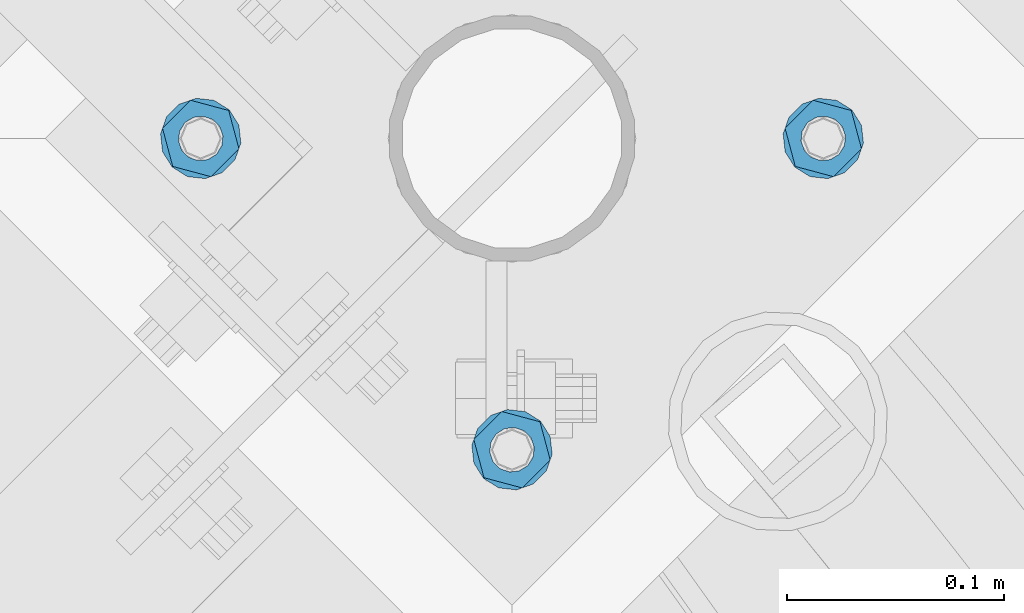
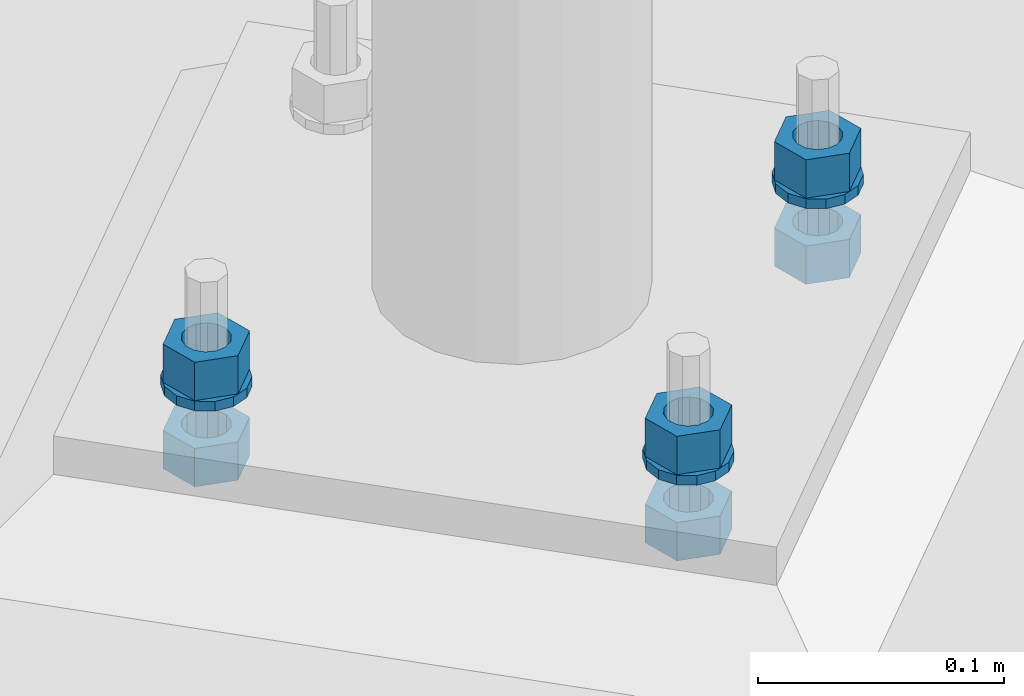
# One storey, part 825 of 975: 9 beams.
"""IFC2X3 building model written with IfcOpenShell, lengths in millimetres."""

from ifc_helpers import new_model, si_unit, frame, origin_with_axes, place, context, subcontext, project, spatial, faceted_brep, material, type_object, element, save


model = new_model("IFC2X3")

# Units and contexts
model_context = context("Model", 3, precision=1e-05, world=origin_with_axes())
body_context = subcontext(model_context, "Body", "Model", "MODEL_VIEW")
ifc_project = project(units=[si_unit("LENGTHUNIT", "METRE", prefix="MILLI"), si_unit("AREAUNIT", "SQUARE_METRE"), si_unit("VOLUMEUNIT", "CUBIC_METRE"), si_unit("MASSUNIT", "GRAM", prefix="KILO"), si_unit("TIMEUNIT", "SECOND"), si_unit("PLANEANGLEUNIT", "RADIAN"), si_unit("SOLIDANGLEUNIT", "STERADIAN"), si_unit("THERMODYNAMICTEMPERATUREUNIT", "DEGREE_CELSIUS"), si_unit("LUMINOUSINTENSITYUNIT", "LUMEN")], contexts=[model_context])

# Site, building, storey
site_placement = place(None, origin_with_axes())
site = spatial("IfcSite", under=ifc_project, at=site_placement, CompositionType="ELEMENT")
building_placement = place(site_placement, origin_with_axes())
building = spatial("IfcBuilding", under=site, at=building_placement, Name="Undefined", CompositionType="ELEMENT")
storey_placement = place(building_placement, origin_with_axes())
storey = spatial("IfcBuildingStorey", under=building, at=storey_placement, Name="Undefined", CompositionType="ELEMENT", Elevation=0.0)

# Beams
ifc_material = material(Name="STEEL/A36")
beam_type_1 = type_object("IfcBeamType", Name="3/4_WASHER", PredefinedType="NOTDEFINED")
beam_1_placement = place(storey_placement, frame((35537.7749989074, 12953.1909055685, -242.8875), z_axis=(0.707106781186513, -0.707106781186582, 3.1377567211166e-14), x_axis=(0.0, 0.0, -1.0)))
element("IfcBeam", 1, at=beam_1_placement, inside=storey, type_object=beam_type_1, material=ifc_material, Name="WASHER", ObjectType="3/4_WASHER", context=body_context, shape_type="Brep", body=[
    faceted_brep([(0.0, -18.6499996185303, 0.0), (0.0, -16.8030690426876, -8.09193156902904), (4.76250000000073, -16.8030690426876, -8.09193156902904), (4.76250000000073, -18.6499996185303, 0.0), (0.0, -11.6280845668225, -14.5811568497838), (4.76250000000073, -11.6280845668225, -14.5811568497838), (0.0, -4.15001533340001, -18.1824051902857), (4.76250000000073, -4.15001533340001, -18.1824051902857), (0.0, 4.15001533340001, -18.1824051902857), (4.76250000000073, 4.15001533340001, -18.1824051902857), (0.0, 11.6280845668234, -14.5811568497838), (4.76250000000073, 11.6280845668234, -14.5811568497838), (0.0, 16.8030690426876, -8.09193156902904), (4.76250000000073, 16.8030690426876, -8.09193156902904), (0.0, 18.6499996185303, 0.0), (4.76250000000073, 18.6499996185303, 0.0), (0.0, 16.8030690426876, 8.09193156902904), (4.76250000000073, 16.8030690426876, 8.09193156902904), (0.0, 11.6280845668225, 14.5811568497838), (4.76250000000073, 11.6280845668225, 14.5811568497838), (0.0, 4.15001533340001, 18.1824051902857), (4.76250000000073, 4.15001533340001, 18.1824051902857), (0.0, -4.15001533340001, 18.1824051902857), (4.76250000000073, -4.15001533340001, 18.1824051902857), (0.0, -11.6280845668234, 14.5811568497838), (4.76250000000073, -11.6280845668234, 14.5811568497838), (0.0, -16.8030690426876, 8.09193156902904), (4.76250000000073, -16.8030690426876, 8.09193156902904), (0.0, 0.0, 10.3199996948242), (0.0, 4.47768005528269, 9.29799844179911), (4.76250000000073, 4.47768005528269, 9.29799844179911), (4.76250000000073, 0.0, 10.3199996948242), (0.0, 8.06850066047446, 6.43441456490817), (4.76250000000073, 8.06850066047446, 6.43441456490817), (0.0, 10.0612557561917, 2.29641597052117), (4.76250000000073, 10.0612557561917, 2.29641597052117), (0.0, 10.0612557561917, -2.29641597052117), (4.76250000000073, 10.0612557561917, -2.29641597052117), (0.0, 8.06850066047446, -6.43441456490814), (4.76250000000073, 8.06850066047446, -6.43441456490814), (0.0, 4.47768005528269, -9.29799844179908), (4.76250000000073, 4.47768005528269, -9.29799844179908), (0.0, 0.0, -10.3199996948242), (4.76250000000073, 0.0, -10.3199996948242), (0.0, -4.47768005528269, -9.29799844179911), (4.76250000000073, -4.47768005528269, -9.29799844179911), (0.0, -8.06850066047446, -6.43441456490817), (4.76250000000073, -8.06850066047446, -6.43441456490817), (0.0, -10.0612557561917, -2.29641597052117), (4.76250000000073, -10.0612557561917, -2.29641597052117), (0.0, -10.0612557561917, 2.29641597052117), (4.76250000000073, -10.0612557561917, 2.29641597052117), (0.0, -8.06850066047446, 6.43441456490814), (4.76250000000073, -8.06850066047446, 6.43441456490814), (0.0, -4.47768005528269, 9.29799844179908), (4.76250000000073, -4.47768005528269, 9.29799844179908)], [[[0, 1, 2, 3]], [[1, 4, 5, 2]], [[4, 6, 7, 5]], [[6, 8, 9, 7]], [[8, 10, 11, 9]], [[10, 12, 13, 11]], [[12, 14, 15, 13]], [[14, 16, 17, 15]], [[16, 18, 19, 17]], [[18, 20, 21, 19]], [[20, 22, 23, 21]], [[22, 24, 25, 23]], [[24, 26, 27, 25]], [[26, 0, 3, 27]], [[28, 29, 30, 31]], [[29, 32, 33, 30]], [[32, 34, 35, 33]], [[34, 36, 37, 35]], [[36, 38, 39, 37]], [[38, 40, 41, 39]], [[40, 42, 43, 41]], [[42, 44, 45, 43]], [[44, 46, 47, 45]], [[46, 48, 49, 47]], [[48, 50, 51, 49]], [[50, 52, 53, 51]], [[52, 54, 55, 53]], [[54, 28, 31, 55]], [[5, 7, 9, 11, 13, 15, 17, 19, 21, 23, 25, 27, 3, 2], [33, 35, 37, 39, 41, 43, 45, 47, 49, 51, 53, 55, 31, 30]], [[26, 24, 22, 20, 18, 16, 14, 12, 10, 8, 6, 4, 1, 0], [54, 52, 50, 48, 46, 44, 42, 40, 38, 36, 34, 32, 29, 28]]]),
])
beam_2_placement = place(storey_placement, frame((35681.4590946862, 13096.8750013477, -242.8875), z_axis=(-0.707106781186601, 0.707106781186494, 2.36468622460961e-14), x_axis=(0.0, 0.0, -1.0)))
element("IfcBeam", 2, at=beam_2_placement, inside=storey, type_object=beam_type_1, material=ifc_material, Name="WASHER", ObjectType="3/4_WASHER", context=body_context, shape_type="Brep", body=[
    faceted_brep([(0.0, -18.6499996185303, 0.0), (0.0, -16.8030690426876, -8.09193156902904), (4.76250000000073, -16.8030690426876, -8.09193156902904), (4.76250000000073, -18.6499996185303, 0.0), (0.0, -11.6280845668225, -14.5811568497838), (4.76250000000073, -11.6280845668225, -14.5811568497838), (0.0, -4.15001533340001, -18.1824051902857), (4.76250000000073, -4.15001533340001, -18.1824051902857), (0.0, 4.15001533340001, -18.1824051902857), (4.76250000000073, 4.15001533340001, -18.1824051902857), (0.0, 11.6280845668234, -14.5811568497838), (4.76250000000073, 11.6280845668234, -14.5811568497838), (0.0, 16.8030690426876, -8.09193156902904), (4.76250000000073, 16.8030690426876, -8.09193156902904), (0.0, 18.6499996185303, 0.0), (4.76250000000073, 18.6499996185303, 0.0), (0.0, 16.8030690426876, 8.09193156902904), (4.76250000000073, 16.8030690426876, 8.09193156902904), (0.0, 11.6280845668225, 14.5811568497838), (4.76250000000073, 11.6280845668225, 14.5811568497838), (0.0, 4.15001533340001, 18.1824051902857), (4.76250000000073, 4.15001533340001, 18.1824051902857), (0.0, -4.15001533340001, 18.1824051902857), (4.76250000000073, -4.15001533340001, 18.1824051902857), (0.0, -11.6280845668234, 14.5811568497838), (4.76250000000073, -11.6280845668234, 14.5811568497838), (0.0, -16.8030690426876, 8.09193156902904), (4.76250000000073, -16.8030690426876, 8.09193156902904), (0.0, 0.0, 10.3199996948242), (0.0, 4.47768005528269, 9.29799844179911), (4.76250000000073, 4.47768005528269, 9.29799844179911), (4.76250000000073, 0.0, 10.3199996948242), (0.0, 8.06850066047446, 6.43441456490817), (4.76250000000073, 8.06850066047446, 6.43441456490817), (0.0, 10.0612557561917, 2.29641597052117), (4.76250000000073, 10.0612557561917, 2.29641597052117), (0.0, 10.0612557561917, -2.29641597052117), (4.76250000000073, 10.0612557561917, -2.29641597052117), (0.0, 8.06850066047446, -6.43441456490814), (4.76250000000073, 8.06850066047446, -6.43441456490814), (0.0, 4.47768005528269, -9.29799844179908), (4.76250000000073, 4.47768005528269, -9.29799844179908), (0.0, 0.0, -10.3199996948242), (4.76250000000073, 0.0, -10.3199996948242), (0.0, -4.47768005528269, -9.29799844179911), (4.76250000000073, -4.47768005528269, -9.29799844179911), (0.0, -8.06850066047446, -6.43441456490817), (4.76250000000073, -8.06850066047446, -6.43441456490817), (0.0, -10.0612557561917, -2.29641597052117), (4.76250000000073, -10.0612557561917, -2.29641597052117), (0.0, -10.0612557561917, 2.29641597052117), (4.76250000000073, -10.0612557561917, 2.29641597052117), (0.0, -8.06850066047446, 6.43441456490814), (4.76250000000073, -8.06850066047446, 6.43441456490814), (0.0, -4.47768005528269, 9.29799844179908), (4.76250000000073, -4.47768005528269, 9.29799844179908)], [[[0, 1, 2, 3]], [[1, 4, 5, 2]], [[4, 6, 7, 5]], [[6, 8, 9, 7]], [[8, 10, 11, 9]], [[10, 12, 13, 11]], [[12, 14, 15, 13]], [[14, 16, 17, 15]], [[16, 18, 19, 17]], [[18, 20, 21, 19]], [[20, 22, 23, 21]], [[22, 24, 25, 23]], [[24, 26, 27, 25]], [[26, 0, 3, 27]], [[28, 29, 30, 31]], [[29, 32, 33, 30]], [[32, 34, 35, 33]], [[34, 36, 37, 35]], [[36, 38, 39, 37]], [[38, 40, 41, 39]], [[40, 42, 43, 41]], [[42, 44, 45, 43]], [[44, 46, 47, 45]], [[46, 48, 49, 47]], [[48, 50, 51, 49]], [[50, 52, 53, 51]], [[52, 54, 55, 53]], [[54, 28, 31, 55]], [[5, 7, 9, 11, 13, 15, 17, 19, 21, 23, 25, 27, 3, 2], [33, 35, 37, 39, 41, 43, 45, 47, 49, 51, 53, 55, 31, 30]], [[26, 24, 22, 20, 18, 16, 14, 12, 10, 8, 6, 4, 1, 0], [54, 52, 50, 48, 46, 44, 42, 40, 38, 36, 34, 32, 29, 28]]]),
])
beam_3_placement = place(storey_placement, frame((35394.0909031286, 13096.8750013477, -242.8875), z_axis=(0.707106781186513, -0.707106781186582, 3.1377567211166e-14), x_axis=(0.0, 0.0, -1.0)))
element("IfcBeam", 3, at=beam_3_placement, inside=storey, type_object=beam_type_1, material=ifc_material, Name="WASHER", ObjectType="3/4_WASHER", context=body_context, shape_type="Brep", body=[
    faceted_brep([(0.0, -18.6499996185303, 0.0), (0.0, -16.8030690426876, -8.09193156902904), (4.76250000000073, -16.8030690426876, -8.09193156902904), (4.76250000000073, -18.6499996185303, 0.0), (0.0, -11.6280845668225, -14.5811568497838), (4.76250000000073, -11.6280845668225, -14.5811568497838), (0.0, -4.15001533340001, -18.1824051902857), (4.76250000000073, -4.15001533340001, -18.1824051902857), (0.0, 4.15001533340001, -18.1824051902857), (4.76250000000073, 4.15001533340001, -18.1824051902857), (0.0, 11.6280845668234, -14.5811568497838), (4.76250000000073, 11.6280845668234, -14.5811568497838), (0.0, 16.8030690426876, -8.09193156902904), (4.76250000000073, 16.8030690426876, -8.09193156902904), (0.0, 18.6499996185303, 0.0), (4.76250000000073, 18.6499996185303, 0.0), (0.0, 16.8030690426876, 8.09193156902904), (4.76250000000073, 16.8030690426876, 8.09193156902904), (0.0, 11.6280845668225, 14.5811568497838), (4.76250000000073, 11.6280845668225, 14.5811568497838), (0.0, 4.15001533340001, 18.1824051902857), (4.76250000000073, 4.15001533340001, 18.1824051902857), (0.0, -4.15001533340001, 18.1824051902857), (4.76250000000073, -4.15001533340001, 18.1824051902857), (0.0, -11.6280845668234, 14.5811568497838), (4.76250000000073, -11.6280845668234, 14.5811568497838), (0.0, -16.8030690426876, 8.09193156902904), (4.76250000000073, -16.8030690426876, 8.09193156902904), (0.0, 0.0, 10.3199996948242), (0.0, 4.47768005528269, 9.29799844179911), (4.76250000000073, 4.47768005528269, 9.29799844179911), (4.76250000000073, 0.0, 10.3199996948242), (0.0, 8.06850066047446, 6.43441456490817), (4.76250000000073, 8.06850066047446, 6.43441456490817), (0.0, 10.0612557561917, 2.29641597052117), (4.76250000000073, 10.0612557561917, 2.29641597052117), (0.0, 10.0612557561917, -2.29641597052117), (4.76250000000073, 10.0612557561917, -2.29641597052117), (0.0, 8.06850066047446, -6.43441456490814), (4.76250000000073, 8.06850066047446, -6.43441456490814), (0.0, 4.47768005528269, -9.29799844179908), (4.76250000000073, 4.47768005528269, -9.29799844179908), (0.0, 0.0, -10.3199996948242), (4.76250000000073, 0.0, -10.3199996948242), (0.0, -4.47768005528269, -9.29799844179911), (4.76250000000073, -4.47768005528269, -9.29799844179911), (0.0, -8.06850066047446, -6.43441456490817), (4.76250000000073, -8.06850066047446, -6.43441456490817), (0.0, -10.0612557561917, -2.29641597052117), (4.76250000000073, -10.0612557561917, -2.29641597052117), (0.0, -10.0612557561917, 2.29641597052117), (4.76250000000073, -10.0612557561917, 2.29641597052117), (0.0, -8.06850066047446, 6.43441456490814), (4.76250000000073, -8.06850066047446, 6.43441456490814), (0.0, -4.47768005528269, 9.29799844179908), (4.76250000000073, -4.47768005528269, 9.29799844179908)], [[[0, 1, 2, 3]], [[1, 4, 5, 2]], [[4, 6, 7, 5]], [[6, 8, 9, 7]], [[8, 10, 11, 9]], [[10, 12, 13, 11]], [[12, 14, 15, 13]], [[14, 16, 17, 15]], [[16, 18, 19, 17]], [[18, 20, 21, 19]], [[20, 22, 23, 21]], [[22, 24, 25, 23]], [[24, 26, 27, 25]], [[26, 0, 3, 27]], [[28, 29, 30, 31]], [[29, 32, 33, 30]], [[32, 34, 35, 33]], [[34, 36, 37, 35]], [[36, 38, 39, 37]], [[38, 40, 41, 39]], [[40, 42, 43, 41]], [[42, 44, 45, 43]], [[44, 46, 47, 45]], [[46, 48, 49, 47]], [[48, 50, 51, 49]], [[50, 52, 53, 51]], [[52, 54, 55, 53]], [[54, 28, 31, 55]], [[5, 7, 9, 11, 13, 15, 17, 19, 21, 23, 25, 27, 3, 2], [33, 35, 37, 39, 41, 43, 45, 47, 49, 51, 53, 55, 31, 30]], [[26, 24, 22, 20, 18, 16, 14, 12, 10, 8, 6, 4, 1, 0], [54, 52, 50, 48, 46, 44, 42, 40, 38, 36, 34, 32, 29, 28]]]),
])
beam_type_2 = type_object("IfcBeamType", Name="3/4_HEAVY_HEX_NUT", PredefinedType="NOTDEFINED")
beam_4_placement = place(storey_placement, frame((35537.7749989074, 12953.1909055685, -223.837500000001), z_axis=(0.707106781186513, -0.707106781186582, 3.1377567211166e-14), x_axis=(0.0, 0.0, -1.0)))
element("IfcBeam", 4, at=beam_4_placement, inside=storey, type_object=beam_type_2, material=ifc_material, Name="NUT", ObjectType="3/4_HEAVY_HEX_NUT", context=body_context, shape_type="Brep", body=[
    faceted_brep([(0.0, -18.2600002288818, 0.0), (0.0, -9.13000011444092, -15.8100004196167), (19.0499999999993, -9.13000011444092, -15.8100004196167), (19.0499999999993, -18.2600002288818, 0.0), (0.0, 9.13000011444092, -15.8100004196167), (19.0499999999993, 9.13000011444092, -15.8100004196167), (0.0, 18.2600002288818, 0.0), (19.0499999999993, 18.2600002288818, 0.0), (0.0, 9.13000011444092, 15.8100004196167), (19.0499999999993, 9.13000011444092, 15.8100004196167), (0.0, -9.13000011444092, 15.8100004196167), (19.0499999999993, -9.13000011444092, 15.8100004196167), (0.0, 0.0, 10.3199996948242), (0.0, 4.47768005528269, 9.29799844179911), (19.0499999999993, 4.47768005528269, 9.29799844179911), (19.0499999999993, 0.0, 10.3199996948242), (0.0, 8.06850066047446, 6.43441456490817), (19.0499999999993, 8.06850066047446, 6.43441456490817), (0.0, 10.0612557561917, 2.29641597052117), (19.0499999999993, 10.0612557561917, 2.29641597052117), (0.0, 10.0612557561917, -2.29641597052117), (19.0499999999993, 10.0612557561917, -2.29641597052117), (0.0, 8.06850066047446, -6.43441456490814), (19.0499999999993, 8.06850066047446, -6.43441456490814), (0.0, 4.47768005528269, -9.29799844179908), (19.0499999999993, 4.47768005528269, -9.29799844179908), (0.0, 0.0, -10.3199996948242), (19.0499999999993, 0.0, -10.3199996948242), (0.0, -4.47768005528269, -9.29799844179911), (19.0499999999993, -4.47768005528269, -9.29799844179911), (0.0, -8.06850066047446, -6.43441456490817), (19.0499999999993, -8.06850066047446, -6.43441456490817), (0.0, -10.0612557561917, -2.29641597052117), (19.0499999999993, -10.0612557561917, -2.29641597052117), (0.0, -10.0612557561917, 2.29641597052117), (19.0499999999993, -10.0612557561917, 2.29641597052117), (0.0, -8.06850066047446, 6.43441456490814), (19.0499999999993, -8.06850066047446, 6.43441456490814), (0.0, -4.47768005528269, 9.29799844179908), (19.0499999999993, -4.47768005528269, 9.29799844179908)], [[[0, 1, 2, 3]], [[1, 4, 5, 2]], [[4, 6, 7, 5]], [[6, 8, 9, 7]], [[8, 10, 11, 9]], [[10, 0, 3, 11]], [[12, 13, 14, 15]], [[13, 16, 17, 14]], [[16, 18, 19, 17]], [[18, 20, 21, 19]], [[20, 22, 23, 21]], [[22, 24, 25, 23]], [[24, 26, 27, 25]], [[26, 28, 29, 27]], [[28, 30, 31, 29]], [[30, 32, 33, 31]], [[32, 34, 35, 33]], [[34, 36, 37, 35]], [[36, 38, 39, 37]], [[38, 12, 15, 39]], [[5, 7, 9, 11, 3, 2], [17, 19, 21, 23, 25, 27, 29, 31, 33, 35, 37, 39, 15, 14]], [[10, 8, 6, 4, 1, 0], [38, 36, 34, 32, 30, 28, 26, 24, 22, 20, 18, 16, 13, 12]]]),
])
beam_5_placement = place(storey_placement, frame((35681.4590946862, 13096.8750013477, -223.837500000001), z_axis=(-0.707106781186601, 0.707106781186494, 2.36468622460961e-14), x_axis=(0.0, 0.0, -1.0)))
element("IfcBeam", 5, at=beam_5_placement, inside=storey, type_object=beam_type_2, material=ifc_material, Name="NUT", ObjectType="3/4_HEAVY_HEX_NUT", context=body_context, shape_type="Brep", body=[
    faceted_brep([(0.0, -18.2600002288818, 0.0), (0.0, -9.13000011444092, -15.8100004196167), (19.0499999999993, -9.13000011444092, -15.8100004196167), (19.0499999999993, -18.2600002288818, 0.0), (0.0, 9.13000011444092, -15.8100004196167), (19.0499999999993, 9.13000011444092, -15.8100004196167), (0.0, 18.2600002288818, 0.0), (19.0499999999993, 18.2600002288818, 0.0), (0.0, 9.13000011444092, 15.8100004196167), (19.0499999999993, 9.13000011444092, 15.8100004196167), (0.0, -9.13000011444092, 15.8100004196167), (19.0499999999993, -9.13000011444092, 15.8100004196167), (0.0, 0.0, 10.3199996948242), (0.0, 4.47768005528269, 9.29799844179911), (19.0499999999993, 4.47768005528269, 9.29799844179911), (19.0499999999993, 0.0, 10.3199996948242), (0.0, 8.06850066047446, 6.43441456490817), (19.0499999999993, 8.06850066047446, 6.43441456490817), (0.0, 10.0612557561917, 2.29641597052117), (19.0499999999993, 10.0612557561917, 2.29641597052117), (0.0, 10.0612557561917, -2.29641597052117), (19.0499999999993, 10.0612557561917, -2.29641597052117), (0.0, 8.06850066047446, -6.43441456490814), (19.0499999999993, 8.06850066047446, -6.43441456490814), (0.0, 4.47768005528269, -9.29799844179908), (19.0499999999993, 4.47768005528269, -9.29799844179908), (0.0, 0.0, -10.3199996948242), (19.0499999999993, 0.0, -10.3199996948242), (0.0, -4.47768005528269, -9.29799844179911), (19.0499999999993, -4.47768005528269, -9.29799844179911), (0.0, -8.06850066047446, -6.43441456490817), (19.0499999999993, -8.06850066047446, -6.43441456490817), (0.0, -10.0612557561917, -2.29641597052117), (19.0499999999993, -10.0612557561917, -2.29641597052117), (0.0, -10.0612557561917, 2.29641597052117), (19.0499999999993, -10.0612557561917, 2.29641597052117), (0.0, -8.06850066047446, 6.43441456490814), (19.0499999999993, -8.06850066047446, 6.43441456490814), (0.0, -4.47768005528269, 9.29799844179908), (19.0499999999993, -4.47768005528269, 9.29799844179908)], [[[0, 1, 2, 3]], [[1, 4, 5, 2]], [[4, 6, 7, 5]], [[6, 8, 9, 7]], [[8, 10, 11, 9]], [[10, 0, 3, 11]], [[12, 13, 14, 15]], [[13, 16, 17, 14]], [[16, 18, 19, 17]], [[18, 20, 21, 19]], [[20, 22, 23, 21]], [[22, 24, 25, 23]], [[24, 26, 27, 25]], [[26, 28, 29, 27]], [[28, 30, 31, 29]], [[30, 32, 33, 31]], [[32, 34, 35, 33]], [[34, 36, 37, 35]], [[36, 38, 39, 37]], [[38, 12, 15, 39]], [[5, 7, 9, 11, 3, 2], [17, 19, 21, 23, 25, 27, 29, 31, 33, 35, 37, 39, 15, 14]], [[10, 8, 6, 4, 1, 0], [38, 36, 34, 32, 30, 28, 26, 24, 22, 20, 18, 16, 13, 12]]]),
])
beam_6_placement = place(storey_placement, frame((35394.0909031286, 13096.8750013477, -223.837500000001), z_axis=(0.707106781186513, -0.707106781186582, 3.1377567211166e-14), x_axis=(0.0, 0.0, -1.0)))
element("IfcBeam", 6, at=beam_6_placement, inside=storey, type_object=beam_type_2, material=ifc_material, Name="NUT", ObjectType="3/4_HEAVY_HEX_NUT", context=body_context, shape_type="Brep", body=[
    faceted_brep([(0.0, -18.2600002288818, 0.0), (0.0, -9.13000011444092, -15.8100004196167), (19.0499999999993, -9.13000011444092, -15.8100004196167), (19.0499999999993, -18.2600002288818, 0.0), (0.0, 9.13000011444092, -15.8100004196167), (19.0499999999993, 9.13000011444092, -15.8100004196167), (0.0, 18.2600002288818, 0.0), (19.0499999999993, 18.2600002288818, 0.0), (0.0, 9.13000011444092, 15.8100004196167), (19.0499999999993, 9.13000011444092, 15.8100004196167), (0.0, -9.13000011444092, 15.8100004196167), (19.0499999999993, -9.13000011444092, 15.8100004196167), (0.0, 0.0, 10.3199996948242), (0.0, 4.47768005528269, 9.29799844179911), (19.0499999999993, 4.47768005528269, 9.29799844179911), (19.0499999999993, 0.0, 10.3199996948242), (0.0, 8.06850066047446, 6.43441456490817), (19.0499999999993, 8.06850066047446, 6.43441456490817), (0.0, 10.0612557561917, 2.29641597052117), (19.0499999999993, 10.0612557561917, 2.29641597052117), (0.0, 10.0612557561917, -2.29641597052117), (19.0499999999993, 10.0612557561917, -2.29641597052117), (0.0, 8.06850066047446, -6.43441456490814), (19.0499999999993, 8.06850066047446, -6.43441456490814), (0.0, 4.47768005528269, -9.29799844179908), (19.0499999999993, 4.47768005528269, -9.29799844179908), (0.0, 0.0, -10.3199996948242), (19.0499999999993, 0.0, -10.3199996948242), (0.0, -4.47768005528269, -9.29799844179911), (19.0499999999993, -4.47768005528269, -9.29799844179911), (0.0, -8.06850066047446, -6.43441456490817), (19.0499999999993, -8.06850066047446, -6.43441456490817), (0.0, -10.0612557561917, -2.29641597052117), (19.0499999999993, -10.0612557561917, -2.29641597052117), (0.0, -10.0612557561917, 2.29641597052117), (19.0499999999993, -10.0612557561917, 2.29641597052117), (0.0, -8.06850066047446, 6.43441456490814), (19.0499999999993, -8.06850066047446, 6.43441456490814), (0.0, -4.47768005528269, 9.29799844179908), (19.0499999999993, -4.47768005528269, 9.29799844179908)], [[[0, 1, 2, 3]], [[1, 4, 5, 2]], [[4, 6, 7, 5]], [[6, 8, 9, 7]], [[8, 10, 11, 9]], [[10, 0, 3, 11]], [[12, 13, 14, 15]], [[13, 16, 17, 14]], [[16, 18, 19, 17]], [[18, 20, 21, 19]], [[20, 22, 23, 21]], [[22, 24, 25, 23]], [[24, 26, 27, 25]], [[26, 28, 29, 27]], [[28, 30, 31, 29]], [[30, 32, 33, 31]], [[32, 34, 35, 33]], [[34, 36, 37, 35]], [[36, 38, 39, 37]], [[38, 12, 15, 39]], [[5, 7, 9, 11, 3, 2], [17, 19, 21, 23, 25, 27, 29, 31, 33, 35, 37, 39, 15, 14]], [[10, 8, 6, 4, 1, 0], [38, 36, 34, 32, 30, 28, 26, 24, 22, 20, 18, 16, 13, 12]]]),
])
beam_7_placement = place(storey_placement, frame((35537.7749989074, 12953.1909055685, -266.7), z_axis=(0.707106781186513, -0.707106781186582, 3.1377567211166e-14), x_axis=(0.0, 0.0, -1.0)))
element("IfcBeam", 7, at=beam_7_placement, inside=storey, type_object=beam_type_2, material=ifc_material, Name="NUT", ObjectType="3/4_HEAVY_HEX_NUT", context=body_context, shape_type="Brep", body=[
    faceted_brep([(0.0, -18.2600002288818, 0.0), (0.0, -9.13000011444092, -15.8100004196167), (19.0499999999993, -9.13000011444092, -15.8100004196167), (19.0499999999993, -18.2600002288818, 0.0), (0.0, 9.13000011444092, -15.8100004196167), (19.0499999999993, 9.13000011444092, -15.8100004196167), (0.0, 18.2600002288818, 0.0), (19.0499999999993, 18.2600002288818, 0.0), (0.0, 9.13000011444092, 15.8100004196167), (19.0499999999993, 9.13000011444092, 15.8100004196167), (0.0, -9.13000011444092, 15.8100004196167), (19.0499999999993, -9.13000011444092, 15.8100004196167), (0.0, 0.0, 10.3199996948242), (0.0, 4.47768005528269, 9.29799844179911), (19.0499999999993, 4.47768005528269, 9.29799844179911), (19.0499999999993, 0.0, 10.3199996948242), (0.0, 8.06850066047446, 6.43441456490817), (19.0499999999993, 8.06850066047446, 6.43441456490817), (0.0, 10.0612557561917, 2.29641597052117), (19.0499999999993, 10.0612557561917, 2.29641597052117), (0.0, 10.0612557561917, -2.29641597052117), (19.0499999999993, 10.0612557561917, -2.29641597052117), (0.0, 8.06850066047446, -6.43441456490814), (19.0499999999993, 8.06850066047446, -6.43441456490814), (0.0, 4.47768005528269, -9.29799844179908), (19.0499999999993, 4.47768005528269, -9.29799844179908), (0.0, 0.0, -10.3199996948242), (19.0499999999993, 0.0, -10.3199996948242), (0.0, -4.47768005528269, -9.29799844179911), (19.0499999999993, -4.47768005528269, -9.29799844179911), (0.0, -8.06850066047446, -6.43441456490817), (19.0499999999993, -8.06850066047446, -6.43441456490817), (0.0, -10.0612557561917, -2.29641597052117), (19.0499999999993, -10.0612557561917, -2.29641597052117), (0.0, -10.0612557561917, 2.29641597052117), (19.0499999999993, -10.0612557561917, 2.29641597052117), (0.0, -8.06850066047446, 6.43441456490814), (19.0499999999993, -8.06850066047446, 6.43441456490814), (0.0, -4.47768005528269, 9.29799844179908), (19.0499999999993, -4.47768005528269, 9.29799844179908)], [[[0, 1, 2, 3]], [[1, 4, 5, 2]], [[4, 6, 7, 5]], [[6, 8, 9, 7]], [[8, 10, 11, 9]], [[10, 0, 3, 11]], [[12, 13, 14, 15]], [[13, 16, 17, 14]], [[16, 18, 19, 17]], [[18, 20, 21, 19]], [[20, 22, 23, 21]], [[22, 24, 25, 23]], [[24, 26, 27, 25]], [[26, 28, 29, 27]], [[28, 30, 31, 29]], [[30, 32, 33, 31]], [[32, 34, 35, 33]], [[34, 36, 37, 35]], [[36, 38, 39, 37]], [[38, 12, 15, 39]], [[5, 7, 9, 11, 3, 2], [17, 19, 21, 23, 25, 27, 29, 31, 33, 35, 37, 39, 15, 14]], [[10, 8, 6, 4, 1, 0], [38, 36, 34, 32, 30, 28, 26, 24, 22, 20, 18, 16, 13, 12]]]),
])
beam_8_placement = place(storey_placement, frame((35681.4590946862, 13096.8750013477, -266.7), z_axis=(-0.707106781186601, 0.707106781186494, 2.36468622460961e-14), x_axis=(0.0, 0.0, -1.0)))
element("IfcBeam", 8, at=beam_8_placement, inside=storey, type_object=beam_type_2, material=ifc_material, Name="NUT", ObjectType="3/4_HEAVY_HEX_NUT", context=body_context, shape_type="Brep", body=[
    faceted_brep([(0.0, -18.2600002288818, 0.0), (0.0, -9.13000011444092, -15.8100004196167), (19.0499999999993, -9.13000011444092, -15.8100004196167), (19.0499999999993, -18.2600002288818, 0.0), (0.0, 9.13000011444092, -15.8100004196167), (19.0499999999993, 9.13000011444092, -15.8100004196167), (0.0, 18.2600002288818, 0.0), (19.0499999999993, 18.2600002288818, 0.0), (0.0, 9.13000011444092, 15.8100004196167), (19.0499999999993, 9.13000011444092, 15.8100004196167), (0.0, -9.13000011444092, 15.8100004196167), (19.0499999999993, -9.13000011444092, 15.8100004196167), (0.0, 0.0, 10.3199996948242), (0.0, 4.47768005528269, 9.29799844179911), (19.0499999999993, 4.47768005528269, 9.29799844179911), (19.0499999999993, 0.0, 10.3199996948242), (0.0, 8.06850066047446, 6.43441456490817), (19.0499999999993, 8.06850066047446, 6.43441456490817), (0.0, 10.0612557561917, 2.29641597052117), (19.0499999999993, 10.0612557561917, 2.29641597052117), (0.0, 10.0612557561917, -2.29641597052117), (19.0499999999993, 10.0612557561917, -2.29641597052117), (0.0, 8.06850066047446, -6.43441456490814), (19.0499999999993, 8.06850066047446, -6.43441456490814), (0.0, 4.47768005528269, -9.29799844179908), (19.0499999999993, 4.47768005528269, -9.29799844179908), (0.0, 0.0, -10.3199996948242), (19.0499999999993, 0.0, -10.3199996948242), (0.0, -4.47768005528269, -9.29799844179911), (19.0499999999993, -4.47768005528269, -9.29799844179911), (0.0, -8.06850066047446, -6.43441456490817), (19.0499999999993, -8.06850066047446, -6.43441456490817), (0.0, -10.0612557561917, -2.29641597052117), (19.0499999999993, -10.0612557561917, -2.29641597052117), (0.0, -10.0612557561917, 2.29641597052117), (19.0499999999993, -10.0612557561917, 2.29641597052117), (0.0, -8.06850066047446, 6.43441456490814), (19.0499999999993, -8.06850066047446, 6.43441456490814), (0.0, -4.47768005528269, 9.29799844179908), (19.0499999999993, -4.47768005528269, 9.29799844179908)], [[[0, 1, 2, 3]], [[1, 4, 5, 2]], [[4, 6, 7, 5]], [[6, 8, 9, 7]], [[8, 10, 11, 9]], [[10, 0, 3, 11]], [[12, 13, 14, 15]], [[13, 16, 17, 14]], [[16, 18, 19, 17]], [[18, 20, 21, 19]], [[20, 22, 23, 21]], [[22, 24, 25, 23]], [[24, 26, 27, 25]], [[26, 28, 29, 27]], [[28, 30, 31, 29]], [[30, 32, 33, 31]], [[32, 34, 35, 33]], [[34, 36, 37, 35]], [[36, 38, 39, 37]], [[38, 12, 15, 39]], [[5, 7, 9, 11, 3, 2], [17, 19, 21, 23, 25, 27, 29, 31, 33, 35, 37, 39, 15, 14]], [[10, 8, 6, 4, 1, 0], [38, 36, 34, 32, 30, 28, 26, 24, 22, 20, 18, 16, 13, 12]]]),
])
beam_9_placement = place(storey_placement, frame((35394.0909031286, 13096.8750013477, -266.7), z_axis=(0.707106781186513, -0.707106781186582, 3.1377567211166e-14), x_axis=(0.0, 0.0, -1.0)))
element("IfcBeam", 9, at=beam_9_placement, inside=storey, type_object=beam_type_2, material=ifc_material, Name="NUT", ObjectType="3/4_HEAVY_HEX_NUT", context=body_context, shape_type="Brep", body=[
    faceted_brep([(0.0, -18.2600002288818, 0.0), (0.0, -9.13000011444092, -15.8100004196167), (19.0499999999993, -9.13000011444092, -15.8100004196167), (19.0499999999993, -18.2600002288818, 0.0), (0.0, 9.13000011444092, -15.8100004196167), (19.0499999999993, 9.13000011444092, -15.8100004196167), (0.0, 18.2600002288818, 0.0), (19.0499999999993, 18.2600002288818, 0.0), (0.0, 9.13000011444092, 15.8100004196167), (19.0499999999993, 9.13000011444092, 15.8100004196167), (0.0, -9.13000011444092, 15.8100004196167), (19.0499999999993, -9.13000011444092, 15.8100004196167), (0.0, 0.0, 10.3199996948242), (0.0, 4.47768005528269, 9.29799844179911), (19.0499999999993, 4.47768005528269, 9.29799844179911), (19.0499999999993, 0.0, 10.3199996948242), (0.0, 8.06850066047446, 6.43441456490817), (19.0499999999993, 8.06850066047446, 6.43441456490817), (0.0, 10.0612557561917, 2.29641597052117), (19.0499999999993, 10.0612557561917, 2.29641597052117), (0.0, 10.0612557561917, -2.29641597052117), (19.0499999999993, 10.0612557561917, -2.29641597052117), (0.0, 8.06850066047446, -6.43441456490814), (19.0499999999993, 8.06850066047446, -6.43441456490814), (0.0, 4.47768005528269, -9.29799844179908), (19.0499999999993, 4.47768005528269, -9.29799844179908), (0.0, 0.0, -10.3199996948242), (19.0499999999993, 0.0, -10.3199996948242), (0.0, -4.47768005528269, -9.29799844179911), (19.0499999999993, -4.47768005528269, -9.29799844179911), (0.0, -8.06850066047446, -6.43441456490817), (19.0499999999993, -8.06850066047446, -6.43441456490817), (0.0, -10.0612557561917, -2.29641597052117), (19.0499999999993, -10.0612557561917, -2.29641597052117), (0.0, -10.0612557561917, 2.29641597052117), (19.0499999999993, -10.0612557561917, 2.29641597052117), (0.0, -8.06850066047446, 6.43441456490814), (19.0499999999993, -8.06850066047446, 6.43441456490814), (0.0, -4.47768005528269, 9.29799844179908), (19.0499999999993, -4.47768005528269, 9.29799844179908)], [[[0, 1, 2, 3]], [[1, 4, 5, 2]], [[4, 6, 7, 5]], [[6, 8, 9, 7]], [[8, 10, 11, 9]], [[10, 0, 3, 11]], [[12, 13, 14, 15]], [[13, 16, 17, 14]], [[16, 18, 19, 17]], [[18, 20, 21, 19]], [[20, 22, 23, 21]], [[22, 24, 25, 23]], [[24, 26, 27, 25]], [[26, 28, 29, 27]], [[28, 30, 31, 29]], [[30, 32, 33, 31]], [[32, 34, 35, 33]], [[34, 36, 37, 35]], [[36, 38, 39, 37]], [[38, 12, 15, 39]], [[5, 7, 9, 11, 3, 2], [17, 19, 21, 23, 25, 27, 29, 31, 33, 35, 37, 39, 15, 14]], [[10, 8, 6, 4, 1, 0], [38, 36, 34, 32, 30, 28, 26, 24, 22, 20, 18, 16, 13, 12]]]),
])

save(model, "model.ifc")
